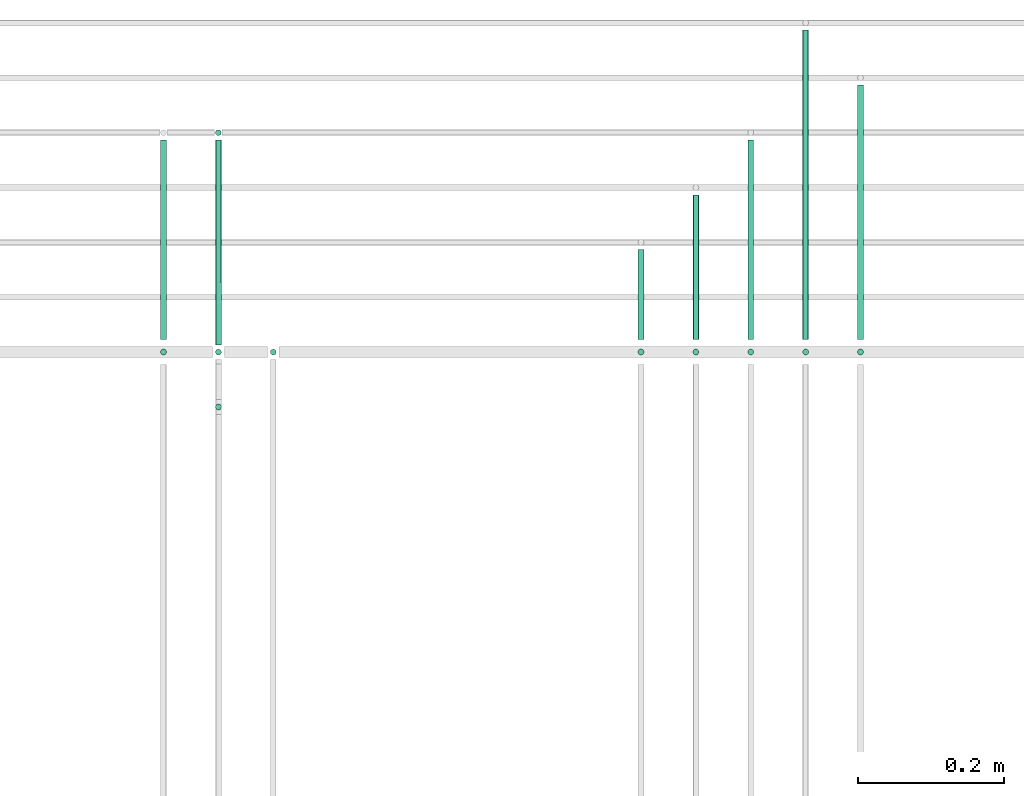
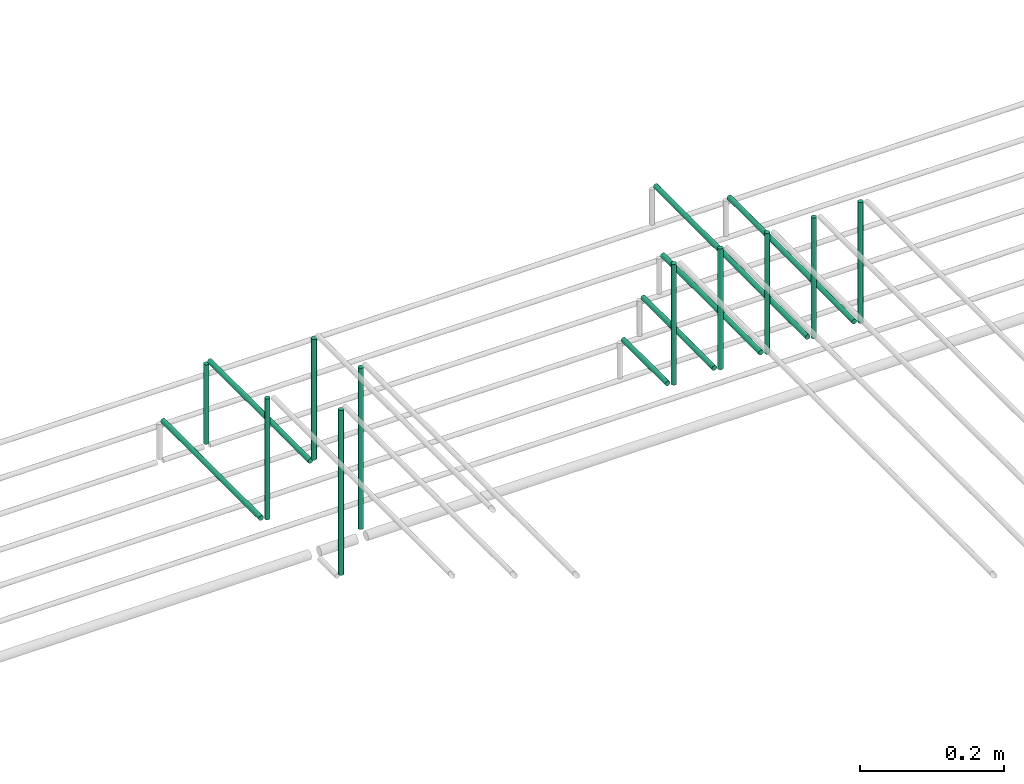
# One storey, part 62 of 89: 17 flow segments.
"""IFC2X3 building model written with IfcOpenShell, lengths in millimetres."""

from ifc_helpers import new_model, entity, si_unit, converted_unit, derived_unit, direction, frame, frame_2d, origin, origin_2d_with_axis, place, context, subcontext, project, spatial, circle, extrude, type_object, element, save


model = new_model("IFC2X3")

# Units and contexts
model_context = context("Model", 3, precision=0.01, world=origin(), true_north=direction((6.12303176911189e-17, 1.0)))
body_context = subcontext(model_context, "Body", "Model", "MODEL_VIEW")
ifc_project = project(units=[si_unit("LENGTHUNIT", "METRE", prefix="MILLI"), si_unit("AREAUNIT", "SQUARE_METRE"), si_unit("VOLUMEUNIT", "CUBIC_METRE"), converted_unit("PLANEANGLEUNIT", "DEGREE", entity("IfcRatioMeasure", 0.0174532925199433), si_unit("PLANEANGLEUNIT", "RADIAN"), dimensions=[0, 0, 0, 0, 0, 0, 0]), si_unit("MASSUNIT", "GRAM", prefix="KILO"), derived_unit("MASSDENSITYUNIT", [(si_unit("MASSUNIT", "GRAM", prefix="KILO"), 1), (si_unit("LENGTHUNIT", "METRE"), -3)]), derived_unit("MOMENTOFINERTIAUNIT", [(si_unit("LENGTHUNIT", "METRE"), 4)]), si_unit("TIMEUNIT", "SECOND"), si_unit("FREQUENCYUNIT", "HERTZ"), si_unit("THERMODYNAMICTEMPERATUREUNIT", "DEGREE_CELSIUS"), derived_unit("THERMALTRANSMITTANCEUNIT", [(si_unit("MASSUNIT", "GRAM", prefix="KILO"), 1), (si_unit("THERMODYNAMICTEMPERATUREUNIT", "KELVIN"), -1), (si_unit("TIMEUNIT", "SECOND"), -3)]), derived_unit("VOLUMETRICFLOWRATEUNIT", [(si_unit("LENGTHUNIT", "METRE"), 3), (si_unit("TIMEUNIT", "SECOND"), -1)]), derived_unit("MASSFLOWRATEUNIT", [(si_unit("MASSUNIT", "GRAM", prefix="KILO"), 1), (si_unit("TIMEUNIT", "SECOND"), -1)]), derived_unit("ROTATIONALFREQUENCYUNIT", [(si_unit("TIMEUNIT", "SECOND"), -1)]), si_unit("ELECTRICCURRENTUNIT", "AMPERE"), si_unit("ELECTRICVOLTAGEUNIT", "VOLT"), si_unit("POWERUNIT", "WATT"), si_unit("FORCEUNIT", "NEWTON", prefix="KILO"), si_unit("ILLUMINANCEUNIT", "LUX"), si_unit("LUMINOUSFLUXUNIT", "LUMEN"), si_unit("LUMINOUSINTENSITYUNIT", "CANDELA"), derived_unit("USERDEFINED", [(si_unit("MASSUNIT", "GRAM", prefix="KILO"), -1), (si_unit("LENGTHUNIT", "METRE"), -2), (si_unit("TIMEUNIT", "SECOND"), 3), (si_unit("LUMINOUSFLUXUNIT", "LUMEN"), 1)]), derived_unit("LINEARVELOCITYUNIT", [(si_unit("LENGTHUNIT", "METRE"), 1), (si_unit("TIMEUNIT", "SECOND"), -1)]), si_unit("PRESSUREUNIT", "PASCAL"), derived_unit("USERDEFINED", [(si_unit("LENGTHUNIT", "METRE"), -2), (si_unit("MASSUNIT", "GRAM", prefix="KILO"), 1), (si_unit("TIMEUNIT", "SECOND"), -2)]), derived_unit("LINEARFORCEUNIT", [(si_unit("MASSUNIT", "GRAM", prefix="KILO"), 1), (si_unit("LENGTHUNIT", "METRE"), 1), (si_unit("TIMEUNIT", "SECOND"), -2), (si_unit("LENGTHUNIT", "METRE"), -1)]), derived_unit("PLANARFORCEUNIT", [(si_unit("MASSUNIT", "GRAM", prefix="KILO"), 1), (si_unit("LENGTHUNIT", "METRE"), 1), (si_unit("TIMEUNIT", "SECOND"), -2), (si_unit("LENGTHUNIT", "METRE"), -2)])], contexts=[model_context])

# Site, building, storey
site_placement = place(None, frame((0.0, -0.00077364408347762, 0.0)))
site = spatial("IfcSite", under=ifc_project, at=site_placement, CompositionType="ELEMENT")
building_placement = place(site_placement, origin())
building = spatial("IfcBuilding", under=site, at=building_placement, CompositionType="ELEMENT")
storey_placement = place(building_placement, frame((0.0, 0.0, 24000.0)))
storey = spatial("IfcBuildingStorey", under=building, at=storey_placement, CompositionType="ELEMENT", Elevation=24000.0)

# Flow segments
pipe_segment_type = type_object("IfcPipeSegmentType", PredefinedType="NOTDEFINED")
flow_segment_1_placement = place(storey_placement, frame((53687.9960651227, 18644.5582806598, 2859.99965095085)))
element("IfcFlowSegment", 1, at=flow_segment_1_placement, inside=storey, type_object=pipe_segment_type, context=body_context, shape_type="SweptSolid", body=[
    extrude(circle(Radius=4.0, at=origin_2d_with_axis()), frame((5.5952722206509, 5.59527223591499, 0.000349592837017099), z_axis=(8.73982106718787e-05, 0.0, 0.999999996180776), x_axis=(0.999999996180776, 0.0, -8.73982106718787e-05)), (0.0, 0.0, 1.0), 205.000000850331),
])
flow_segment_2_placement = place(storey_placement, frame((53687.9965505205, 18667.1535528393, 2844.40472924287)))
element("IfcFlowSegment", 2, at=flow_segment_2_placement, inside=storey, type_object=pipe_segment_type, context=body_context, shape_type="SweptSolid", body=[
    extrude(circle(Radius=4.0, at=origin_2d_with_axis()), frame((5.59527223591499, 0.0, 5.59527223591499), z_axis=(0.0, 1.0, 0.0), x_axis=(-1.0, 0.0, 0.0)), (0.0, 0.0, 1.0), 122.846447160764),
])
for number, where in (
    (3, (53762.9960651227, 18644.5582806598, 2859.99965095085)),
    (4, (53837.9960651227, 18644.5582806598, 2859.99965095085)),
    (5, (53912.9960651227, 18644.5582806598, 2859.99965095085)),
    (6, (53987.9960651227, 18644.5582806598, 2859.99965095085)),
):
    element("IfcFlowSegment", number, at=place(storey_placement, frame(where)), inside=storey, type_object=pipe_segment_type, context=body_context, shape_type="SweptSolid", body=[
        extrude(circle(Radius=4.0, at=origin_2d_with_axis()), frame((5.5952722206509, 5.59527223591499, 0.000349592837017099), z_axis=(8.73982106718787e-05, 0.0, 0.999999996180776), x_axis=(0.999999996180776, 0.0, -8.73982106718787e-05)), (0.0, 0.0, 1.0), 205.000000850331),
    ])
flow_segment_3_placement = place(storey_placement, frame((53762.9965505205, 18667.1535528393, 2844.40472986988)))
element("IfcFlowSegment", 7, at=flow_segment_3_placement, inside=storey, type_object=pipe_segment_type, context=body_context, shape_type="SweptSolid", body=[
    extrude(circle(Radius=4.0, at=origin_2d_with_axis()), frame((5.59527223591499, 0.0, 5.59527223591499), z_axis=(0.0, 1.0, 0.0), x_axis=(-1.0, 0.0, 0.0)), (0.0, 0.0, 1.0), 197.846447160764),
])
flow_segment_4_placement = place(storey_placement, frame((53837.9965505205, 18667.1535528393, 2844.40473042311)))
element("IfcFlowSegment", 8, at=flow_segment_4_placement, inside=storey, type_object=pipe_segment_type, context=body_context, shape_type="SweptSolid", body=[
    extrude(circle(Radius=4.0, at=origin_2d_with_axis()), frame((5.59527223591499, 0.0, 5.59527223591499), z_axis=(0.0, 1.0, 0.0), x_axis=(-1.0, 0.0, 0.0)), (0.0, 0.0, 1.0), 272.84644716076),
])
flow_segment_5_placement = place(storey_placement, frame((53912.9965505205, 18667.1535528393, 2844.40473152958)))
element("IfcFlowSegment", 9, at=flow_segment_5_placement, inside=storey, type_object=pipe_segment_type, context=body_context, shape_type="SweptSolid", body=[
    extrude(circle(Radius=4.0, at=origin_2d_with_axis()), frame((5.59527223591499, 0.0, 5.59527223591499), z_axis=(0.0, 1.0, 0.0), x_axis=(-1.0, 0.0, 0.0)), (0.0, 0.0, 1.0), 422.846447160774),
])
flow_segment_6_placement = place(storey_placement, frame((53987.9965505205, 18667.1535528393, 2844.40473097634)))
element("IfcFlowSegment", 10, at=flow_segment_6_placement, inside=storey, type_object=pipe_segment_type, context=body_context, shape_type="SweptSolid", body=[
    extrude(circle(Radius=4.0, at=origin_2d_with_axis()), frame((5.59527223591499, 0.0, 5.59527223591499), z_axis=(0.0, 1.0, 0.0), x_axis=(-1.0, 0.0, 0.0)), (0.0, 0.0, 1.0), 347.846447160776),
])
flow_segment_7_placement = place(storey_placement, frame((53035.2837362699, 18644.5582806598, 2859.99965095085)))
element("IfcFlowSegment", 11, at=flow_segment_7_placement, inside=storey, type_object=pipe_segment_type, context=body_context, shape_type="SweptSolid", body=[
    extrude(circle(Radius=4.0, at=origin_2d_with_axis()), frame((5.5952722206509, 5.59527223591499, 0.000349592837017099), z_axis=(8.73982106718787e-05, 0.0, 0.999999996180776), x_axis=(0.999999996180776, 0.0, -8.73982106718787e-05)), (0.0, 0.0, 1.0), 205.000000850331),
])
flow_segment_8_placement = place(storey_placement, frame((53035.2179132113, 18667.1535528393, 2844.40473042311)))
element("IfcFlowSegment", 12, at=flow_segment_8_placement, inside=storey, type_object=pipe_segment_type, context=body_context, shape_type="SweptSolid", body=[
    extrude(circle(Radius=4.0, at=origin_2d_with_axis()), frame((5.59527223591499, 0.0, 5.59527223591499), z_axis=(0.0, 1.0, 0.0), x_axis=(-1.0, 0.0, 0.0)), (0.0, 0.0, 1.0), 272.846447160739),
])
flow_segment_9_placement = place(storey_placement, frame((53110.3093686732, 18644.4047277642, 2935.0)))
element("IfcFlowSegment", 13, at=flow_segment_9_placement, inside=storey, type_object=pipe_segment_type, context=body_context, shape_type="SweptSolid", body=[
    extrude(circle(Radius=4.0, at=origin_2d_with_axis()), frame((5.59527223591499, 5.59527223591499, 0.0)), (0.0, 0.0, 1.0), 205.00000000001),
])
flow_segment_10_placement = place(storey_placement, frame((53185.3093686732, 18644.4047277641, 2791.0)))
element("IfcFlowSegment", 14, at=flow_segment_10_placement, inside=storey, type_object=pipe_segment_type, context=body_context, shape_type="SweptSolid", body=[
    extrude(circle(Radius=4.0, at=origin_2d_with_axis()), frame((5.59527223591499, 5.59527223591499, 0.0), z_axis=(0.0, 0.0, 1.0), x_axis=(-1.0, 0.0, 0.0)), (0.0, 0.0, 1.0), 273.999999999972),
])
flow_segment_11_placement = place(storey_placement, frame((53110.221938151, 18659.9987936049, 2919.40472776407)))
element("IfcFlowSegment", 15, at=flow_segment_11_placement, inside=storey, type_object=pipe_segment_type, context=body_context, shape_type="SweptSolid", body=[
    extrude(circle(Radius=4.0, at=frame_2d((-6.28057268585835e-24, 4.33146851719357e-12), x_axis=(1.0, 0.0))), frame((5.67968790637478, 0.0012059406895844, 5.59527223591932), z_axis=(-0.000301485171826274, 0.999999954553345, 0.0), x_axis=(0.999999954553345, 0.000301485171826274, 0.0)), (0.0, 0.0, 1.0), 280.00001370385),
])
flow_segment_12_placement = place(storey_placement, frame((53110.2186997952, 18944.4047277642, 2780.0)))
element("IfcFlowSegment", 16, at=flow_segment_12_placement, inside=storey, type_object=pipe_segment_type, context=body_context, shape_type="SweptSolid", body=[
    extrude(circle(Radius=4.0, at=origin_2d_with_axis()), frame((5.59527223591499, 5.59527223591499, 0.0), z_axis=(0.0, 0.0, 1.0), x_axis=(-1.0, 0.0, 0.0)), (0.0, 0.0, 1.0), 134.999999999991),
])
flow_segment_13_placement = place(storey_placement, frame((53110.3093686732, 18569.4047277642, 2785.0)))
element("IfcFlowSegment", 17, at=flow_segment_13_placement, inside=storey, type_object=pipe_segment_type, context=body_context, shape_type="SweptSolid", body=[
    extrude(circle(Radius=4.0, at=origin_2d_with_axis()), frame((5.59527223591499, 5.59527223591499, 0.0)), (0.0, 0.0, 1.0), 280.000000000014),
])

save(model, "model.ifc")
